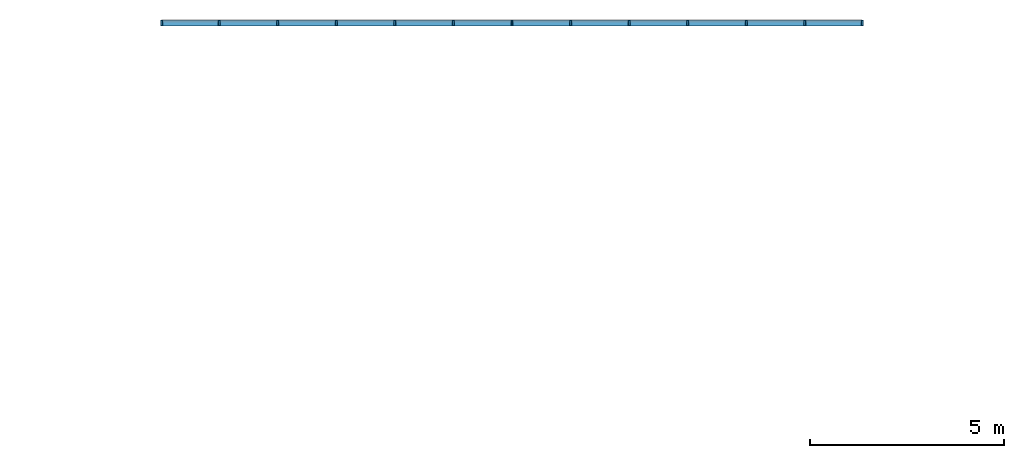
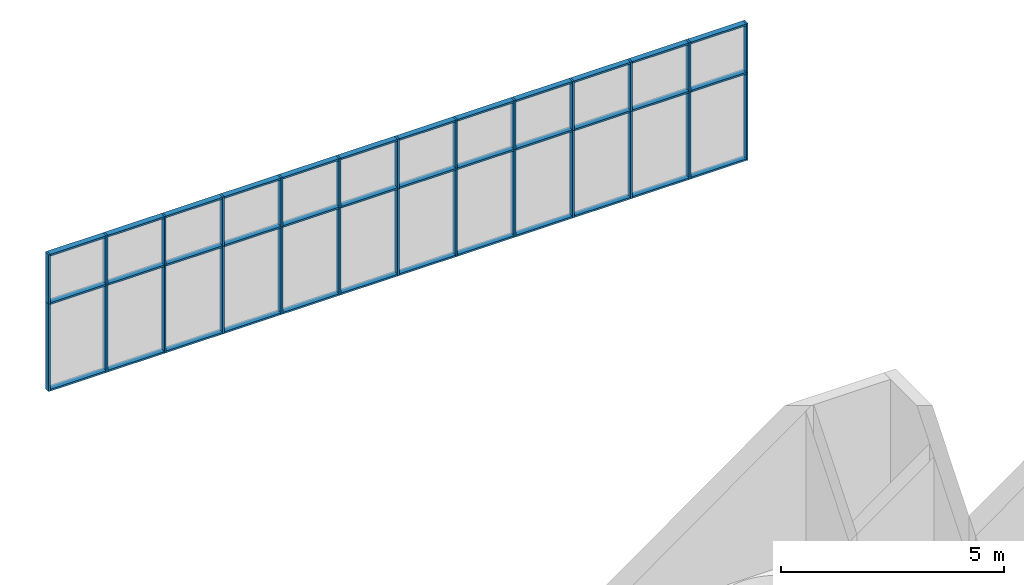
# One storey, part 3 of 11: 62 members, 1 element without a shape of its own.
"""IFC2X3 building model written with IfcOpenShell, lengths in millimetres."""

from ifc_helpers import new_model, entity, si_unit, converted_unit, direction, frame, frame_2d, origin, origin_2d_with_axis, place, context, subcontext, project, spatial, rectangle, extrude, element, aggregate, save


model = new_model("IFC2X3")

# Units and contexts
model_context = context("Model", 3, precision=1e-06, world=origin(), true_north=direction((2.0, 6.12303176911189e-17, 1.0)))
context_of_model = context(None, 3, precision=1e-06, world=origin(), true_north=direction((2.0, 6.12303176911189e-17, 1.0)))
body_context = subcontext(model_context, "Body", "Model", "MODEL_VIEW")
ifc_project = project(units=[si_unit("LENGTHUNIT", "METRE", prefix="MILLI"), si_unit("AREAUNIT", "SQUARE_METRE", prefix="MILLI"), si_unit("VOLUMEUNIT", "CUBIC_METRE", prefix="MILLI"), converted_unit("PLANEANGLEUNIT", "DEGREE", entity("IfcRatioMeasure", 0.0174532925199433), si_unit("PLANEANGLEUNIT", "RADIAN"), dimensions=[0, 0, 0, 0, 0, 0, 0]), si_unit("TIMEUNIT", "SECOND")], contexts=[model_context, context_of_model])

# Site, building, storey
site_placement = place(None, origin())
site = spatial("IfcSite", under=ifc_project, at=site_placement, CompositionType="ELEMENT")
building_placement = place(site_placement, origin())
building = spatial("IfcBuilding", under=site, at=building_placement, CompositionType="ELEMENT")
storey_placement = place(building_placement, frame((0.0, 0.0, 3750.0)))
storey = spatial("IfcBuildingStorey", under=building, at=storey_placement, Name="02. 2 etg.", CompositionType="ELEMENT", Elevation=3750.00000000068)

# Curtain wall, members
curtain_wall_placement = place(storey_placement, origin())
curtain_wall = element("IfcCurtainWall", 1, at=curtain_wall_placement, inside=storey, Name="Curtain Wall:Storefront", ObjectType="Curtain Wall:Storefront")
member_1_placement = place(storey_placement, origin())
member_1 = element("IfcMember", 2, at=member_1_placement, Name="Curtain Wall:Storefront:8486", ObjectType="Curtain Wall:Storefront:8486", context=body_context, shape_type="SweptSolid", body=[
    extrude(rectangle(XDim=1436.66666666667, YDim=150.000000000001, at=frame_2d((0.0, 1.08713038571295e-12), x_axis=(1.0, 0.0))), frame((28730.7845228414, 18980.0, 3700.0), z_axis=(0.0, 0.0, 1.0), x_axis=(-1.0, 0.0, 0.0)), (0.0, 0.0, 1.0), 49.9999999999995),
])
member_2_placement = place(storey_placement, origin())
member_2 = element("IfcMember", 3, at=member_2_placement, Name="Curtain Wall:Storefront:8486", ObjectType="Curtain Wall:Storefront:8486", context=body_context, shape_type="SweptSolid", body=[
    extrude(rectangle(XDim=1436.66666666667, YDim=150.000000000001, at=frame_2d((1.08002495835535e-12, 1.08713038571295e-12), x_axis=(1.0, 0.0))), frame((12127.4511895081, 18980.0, 0.0)), (0.0, 0.0, 1.0), 50.0),
])
member_3_placement = place(storey_placement, origin())
member_3 = element("IfcMember", 4, at=member_3_placement, Name="Curtain Wall:Storefront:8486", ObjectType="Curtain Wall:Storefront:8486", context=body_context, shape_type="SweptSolid", body=[
    extrude(rectangle(XDim=149.999999999998, YDim=50.0000000000016, at=frame_2d((-1.08002495835535e-12, -2.16715534406831e-12), x_axis=(1.0, 0.0))), frame((29474.1178561748, 18980.0, 0.0), z_axis=(0.0, 0.0, 1.0), x_axis=(0.0, 1.0, 0.0)), (0.0, 0.0, 1.0), 2400.0),
])
member_4_placement = place(storey_placement, origin())
member_4 = element("IfcMember", 5, at=member_4_placement, Name="Curtain Wall:Storefront:8486", ObjectType="Curtain Wall:Storefront:8486", context=body_context, shape_type="SweptSolid", body=[
    extrude(rectangle(XDim=49.9999999999995, YDim=149.999999999998, at=frame_2d((2.16715534406831e-12, 1.08002495835535e-12), x_axis=(1.0, 0.0))), frame((11384.1178561748, 18980.0, 2400.0)), (0.0, 0.0, 1.0), 1349.99999999993),
])
member_5_placement = place(storey_placement, origin())
member_5 = element("IfcMember", 6, at=member_5_placement, Name="Curtain Wall:Storefront:8486", ObjectType="Curtain Wall:Storefront:8486", context=body_context, shape_type="SweptSolid", body=[
    extrude(rectangle(XDim=1436.66666666667, YDim=150.000000000001, at=frame_2d((-1.08002495835535e-12, 1.08713038571295e-12), x_axis=(1.0, 0.0))), frame((12127.4511895081, 18980.0, 3700.0), z_axis=(0.0, 0.0, 1.0), x_axis=(-1.0, 0.0, 0.0)), (0.0, 0.0, 1.0), 49.9999999999995),
])
member_6_placement = place(storey_placement, origin())
member_6 = element("IfcMember", 7, at=member_6_placement, Name="Curtain Wall:Storefront:8486", ObjectType="Curtain Wall:Storefront:8486", context=body_context, shape_type="SweptSolid", body=[
    extrude(rectangle(XDim=1461.66666666667, YDim=150.000000000001, at=frame_2d((1.08002495835535e-12, 0.0), x_axis=(1.0, 0.0))), frame((13626.6178561748, 18980.0, 3700.0), z_axis=(0.0, 0.0, 1.0), x_axis=(-1.0, 0.0, 0.0)), (0.0, 0.0, 1.0), 49.9999999999995),
])
member_7_placement = place(storey_placement, origin())
member_7 = element("IfcMember", 8, at=member_7_placement, Name="Curtain Wall:Storefront:8486", ObjectType="Curtain Wall:Storefront:8486", context=body_context, shape_type="SweptSolid", body=[
    extrude(rectangle(XDim=1461.66666666667, YDim=150.000000000001, at=frame_2d((-1.08002495835535e-12, 0.0), x_axis=(1.0, 0.0))), frame((15138.2845228414, 18980.0, 3700.0), z_axis=(0.0, 0.0, 1.0), x_axis=(-1.0, 0.0, 0.0)), (0.0, 0.0, 1.0), 49.9999999999995),
])
member_8_placement = place(storey_placement, origin())
member_8 = element("IfcMember", 9, at=member_8_placement, Name="Curtain Wall:Storefront:8486", ObjectType="Curtain Wall:Storefront:8486", context=body_context, shape_type="SweptSolid", body=[
    extrude(rectangle(XDim=1461.66666666667, YDim=150.000000000001, at=frame_2d((-1.08002495835535e-12, 0.0), x_axis=(1.0, 0.0))), frame((16649.9511895081, 18980.0, 3700.0), z_axis=(0.0, 0.0, 1.0), x_axis=(-1.0, 0.0, 0.0)), (0.0, 0.0, 1.0), 49.9999999999995),
])
member_9_placement = place(storey_placement, origin())
member_9 = element("IfcMember", 10, at=member_9_placement, Name="Curtain Wall:Storefront:8486", ObjectType="Curtain Wall:Storefront:8486", context=body_context, shape_type="SweptSolid", body=[
    extrude(rectangle(XDim=1461.66666666666, YDim=150.000000000001, at=frame_2d((1.08002495835535e-12, 1.08713038571295e-12), x_axis=(1.0, 0.0))), frame((18161.6178561748, 18980.0, 3700.0), z_axis=(0.0, 0.0, 1.0), x_axis=(-1.0, 0.0, 0.0)), (0.0, 0.0, 1.0), 49.9999999999995),
])
member_10_placement = place(storey_placement, origin())
member_10 = element("IfcMember", 11, at=member_10_placement, Name="Curtain Wall:Storefront:8486", ObjectType="Curtain Wall:Storefront:8486", context=body_context, shape_type="SweptSolid", body=[
    extrude(rectangle(XDim=1461.66666666666, YDim=150.000000000001, at=frame_2d((1.08002495835535e-12, 0.0), x_axis=(1.0, 0.0))), frame((19673.2845228414, 18980.0, 3700.0), z_axis=(0.0, 0.0, 1.0), x_axis=(-1.0, 0.0, 0.0)), (0.0, 0.0, 1.0), 49.9999999999995),
])
member_11_placement = place(storey_placement, origin())
member_11 = element("IfcMember", 12, at=member_11_placement, Name="Curtain Wall:Storefront:8486", ObjectType="Curtain Wall:Storefront:8486", context=body_context, shape_type="SweptSolid", body=[
    extrude(rectangle(XDim=1461.66666666666, YDim=150.000000000001, at=frame_2d((0.0, 2.16715534406831e-12), x_axis=(1.0, 0.0))), frame((21184.9511895081, 18980.0, 3700.0), z_axis=(0.0, 0.0, 1.0), x_axis=(-1.0, 0.0, 0.0)), (0.0, 0.0, 1.0), 49.9999999999995),
])
member_12_placement = place(storey_placement, origin())
member_12 = element("IfcMember", 13, at=member_12_placement, Name="Curtain Wall:Storefront:8486", ObjectType="Curtain Wall:Storefront:8486", context=body_context, shape_type="SweptSolid", body=[
    extrude(rectangle(XDim=1461.66666666666, YDim=150.000000000001, at=frame_2d((0.0, 1.08713038571295e-12), x_axis=(1.0, 0.0))), frame((22696.6178561748, 18980.0, 3700.0), z_axis=(0.0, 0.0, 1.0), x_axis=(-1.0, 0.0, 0.0)), (0.0, 0.0, 1.0), 49.9999999999995),
])
member_13_placement = place(storey_placement, origin())
member_13 = element("IfcMember", 14, at=member_13_placement, Name="Curtain Wall:Storefront:8486", ObjectType="Curtain Wall:Storefront:8486", context=body_context, shape_type="SweptSolid", body=[
    extrude(rectangle(XDim=1461.66666666666, YDim=150.000000000001, at=origin_2d_with_axis()), frame((24208.2845228414, 18980.0, 3700.0), z_axis=(0.0, 0.0, 1.0), x_axis=(-1.0, 0.0, 0.0)), (0.0, 0.0, 1.0), 49.9999999999995),
])
member_14_placement = place(storey_placement, origin())
member_14 = element("IfcMember", 15, at=member_14_placement, Name="Curtain Wall:Storefront:8486", ObjectType="Curtain Wall:Storefront:8486", context=body_context, shape_type="SweptSolid", body=[
    extrude(rectangle(XDim=1461.66666666666, YDim=150.000000000001, at=origin_2d_with_axis()), frame((25719.9511895081, 18980.0, 3700.0), z_axis=(0.0, 0.0, 1.0), x_axis=(-1.0, 0.0, 0.0)), (0.0, 0.0, 1.0), 49.9999999999995),
])
member_15_placement = place(storey_placement, origin())
member_15 = element("IfcMember", 16, at=member_15_placement, Name="Curtain Wall:Storefront:8486", ObjectType="Curtain Wall:Storefront:8486", context=body_context, shape_type="SweptSolid", body=[
    extrude(rectangle(XDim=1461.66666666666, YDim=150.000000000001, at=origin_2d_with_axis()), frame((27231.6178561748, 18980.0, 3700.0), z_axis=(0.0, 0.0, 1.0), x_axis=(-1.0, 0.0, 0.0)), (0.0, 0.0, 1.0), 49.9999999999995),
])
member_16_placement = place(storey_placement, origin())
member_16 = element("IfcMember", 17, at=member_16_placement, Name="Curtain Wall:Storefront:8486", ObjectType="Curtain Wall:Storefront:8486", context=body_context, shape_type="SweptSolid", body=[
    extrude(rectangle(XDim=1461.66666666666, YDim=150.000000000001, at=frame_2d((1.08002495835535e-12, 0.0), x_axis=(1.0, 0.0))), frame((13626.6178561748, 18980.0, 0.0)), (0.0, 0.0, 1.0), 50.0),
])
member_17_placement = place(storey_placement, origin())
member_17 = element("IfcMember", 18, at=member_17_placement, Name="Curtain Wall:Storefront:8486", ObjectType="Curtain Wall:Storefront:8486", context=body_context, shape_type="SweptSolid", body=[
    extrude(rectangle(XDim=1461.66666666666, YDim=150.000000000001, at=frame_2d((1.08002495835535e-12, 0.0), x_axis=(1.0, 0.0))), frame((15138.2845228414, 18980.0, 0.0)), (0.0, 0.0, 1.0), 50.0),
])
member_18_placement = place(storey_placement, origin())
member_18 = element("IfcMember", 19, at=member_18_placement, Name="Curtain Wall:Storefront:8486", ObjectType="Curtain Wall:Storefront:8486", context=body_context, shape_type="SweptSolid", body=[
    extrude(rectangle(XDim=1461.66666666666, YDim=150.000000000001, at=frame_2d((-1.08002495835535e-12, 0.0), x_axis=(1.0, 0.0))), frame((16649.9511895081, 18980.0, 0.0)), (0.0, 0.0, 1.0), 50.0),
])
member_19_placement = place(storey_placement, origin())
member_19 = element("IfcMember", 20, at=member_19_placement, Name="Curtain Wall:Storefront:8486", ObjectType="Curtain Wall:Storefront:8486", context=body_context, shape_type="SweptSolid", body=[
    extrude(rectangle(XDim=1461.66666666666, YDim=150.000000000001, at=frame_2d((1.08002495835535e-12, 1.08713038571295e-12), x_axis=(1.0, 0.0))), frame((18161.6178561748, 18980.0, 0.0)), (0.0, 0.0, 1.0), 50.0),
])
member_20_placement = place(storey_placement, origin())
member_20 = element("IfcMember", 21, at=member_20_placement, Name="Curtain Wall:Storefront:8486", ObjectType="Curtain Wall:Storefront:8486", context=body_context, shape_type="SweptSolid", body=[
    extrude(rectangle(XDim=1461.66666666667, YDim=150.000000000001, at=frame_2d((-1.08002495835535e-12, 2.16715534406831e-12), x_axis=(1.0, 0.0))), frame((19673.2845228414, 18980.0, 0.0)), (0.0, 0.0, 1.0), 50.0),
])
member_21_placement = place(storey_placement, origin())
member_21 = element("IfcMember", 22, at=member_21_placement, Name="Curtain Wall:Storefront:8486", ObjectType="Curtain Wall:Storefront:8486", context=body_context, shape_type="SweptSolid", body=[
    extrude(rectangle(XDim=1461.66666666666, YDim=150.000000000001, at=origin_2d_with_axis()), frame((21184.9511895081, 18980.0, 0.0)), (0.0, 0.0, 1.0), 50.0),
])
member_22_placement = place(storey_placement, origin())
member_22 = element("IfcMember", 23, at=member_22_placement, Name="Curtain Wall:Storefront:8486", ObjectType="Curtain Wall:Storefront:8486", context=body_context, shape_type="SweptSolid", body=[
    extrude(rectangle(XDim=1461.66666666666, YDim=150.000000000001, at=frame_2d((0.0, 1.08713038571295e-12), x_axis=(1.0, 0.0))), frame((22696.6178561748, 18980.0, 0.0)), (0.0, 0.0, 1.0), 50.0),
])
member_23_placement = place(storey_placement, origin())
member_23 = element("IfcMember", 24, at=member_23_placement, Name="Curtain Wall:Storefront:8486", ObjectType="Curtain Wall:Storefront:8486", context=body_context, shape_type="SweptSolid", body=[
    extrude(rectangle(XDim=1461.66666666666, YDim=150.000000000001, at=origin_2d_with_axis()), frame((24208.2845228414, 18980.0, 0.0)), (0.0, 0.0, 1.0), 50.0),
])
member_24_placement = place(storey_placement, origin())
member_24 = element("IfcMember", 25, at=member_24_placement, Name="Curtain Wall:Storefront:8486", ObjectType="Curtain Wall:Storefront:8486", context=body_context, shape_type="SweptSolid", body=[
    extrude(rectangle(XDim=1461.66666666666, YDim=150.000000000001, at=origin_2d_with_axis()), frame((25719.9511895081, 18980.0, 0.0)), (0.0, 0.0, 1.0), 50.0),
])
member_25_placement = place(storey_placement, origin())
member_25 = element("IfcMember", 26, at=member_25_placement, Name="Curtain Wall:Storefront:8486", ObjectType="Curtain Wall:Storefront:8486", context=body_context, shape_type="SweptSolid", body=[
    extrude(rectangle(XDim=1461.66666666666, YDim=150.000000000001, at=origin_2d_with_axis()), frame((27231.6178561748, 18980.0, 0.0)), (0.0, 0.0, 1.0), 50.0),
])
member_26_placement = place(storey_placement, origin())
member_26 = element("IfcMember", 27, at=member_26_placement, Name="Curtain Wall:Storefront:8486", ObjectType="Curtain Wall:Storefront:8486", context=body_context, shape_type="SweptSolid", body=[
    extrude(rectangle(XDim=1436.66666666666, YDim=150.000000000001, at=frame_2d((-2.1600499167107e-12, 1.08713038571295e-12), x_axis=(1.0, 0.0))), frame((28730.7845228414, 18980.0, 0.0)), (0.0, 0.0, 1.0), 50.0),
])
member_27_placement = place(storey_placement, origin())
member_27 = element("IfcMember", 28, at=member_27_placement, Name="Curtain Wall:Storefront:8486", ObjectType="Curtain Wall:Storefront:8486", context=body_context, shape_type="SweptSolid", body=[
    extrude(rectangle(XDim=150.000000000001, YDim=50.0000000000016, at=origin_2d_with_axis()), frame((29474.1178561748, 18980.0, 2400.0), z_axis=(0.0, 0.0, 1.0), x_axis=(0.0, 1.0, 0.0)), (0.0, 0.0, 1.0), 1349.99999999993),
])
member_28_placement = place(storey_placement, origin())
member_28 = element("IfcMember", 29, at=member_28_placement, Name="Curtain Wall:Storefront:8486", ObjectType="Curtain Wall:Storefront:8486", context=body_context, shape_type="SweptSolid", body=[
    extrude(rectangle(XDim=50.0000000000016, YDim=150.000000000001, at=origin_2d_with_axis()), frame((11384.1178561748, 18980.0, 0.0)), (0.0, 0.0, 1.0), 2400.0),
])
member_29_placement = place(storey_placement, origin())
member_29 = element("IfcMember", 30, at=member_29_placement, Name="Curtain Wall:Storefront:8486", ObjectType="Curtain Wall:Storefront:8486", context=body_context, shape_type="SweptSolid", body=[
    extrude(rectangle(XDim=1436.66666666667, YDim=150.000000000001, at=frame_2d((1.08002495835535e-12, 1.08713038571295e-12), x_axis=(1.0, 0.0))), frame((12127.4511895081, 18980.0, 2375.0), z_axis=(0.0, 0.0, 1.0), x_axis=(-1.0, 0.0, 0.0)), (0.0, 0.0, 1.0), 49.9999999999995),
])
member_30_placement = place(storey_placement, origin())
member_30 = element("IfcMember", 31, at=member_30_placement, Name="Curtain Wall:Storefront:8486", ObjectType="Curtain Wall:Storefront:8486", context=body_context, shape_type="SweptSolid", body=[
    extrude(rectangle(XDim=1461.66666666667, YDim=149.999999999998, at=frame_2d((1.08002495835535e-12, -1.08002495835535e-12), x_axis=(1.0, 0.0))), frame((13626.6178561748, 18980.0, 2375.0), z_axis=(0.0, 0.0, 1.0), x_axis=(-1.0, 0.0, 0.0)), (0.0, 0.0, 1.0), 49.9999999999995),
])
member_31_placement = place(storey_placement, origin())
member_31 = element("IfcMember", 32, at=member_31_placement, Name="Curtain Wall:Storefront:8486", ObjectType="Curtain Wall:Storefront:8486", context=body_context, shape_type="SweptSolid", body=[
    extrude(rectangle(XDim=1461.66666666667, YDim=149.999999999998, at=frame_2d((-1.08002495835535e-12, 1.08002495835535e-12), x_axis=(1.0, 0.0))), frame((15138.2845228414, 18980.0, 2375.0), z_axis=(0.0, 0.0, 1.0), x_axis=(-1.0, 0.0, 0.0)), (0.0, 0.0, 1.0), 49.9999999999995),
])
member_32_placement = place(storey_placement, origin())
member_32 = element("IfcMember", 33, at=member_32_placement, Name="Curtain Wall:Storefront:8486", ObjectType="Curtain Wall:Storefront:8486", context=body_context, shape_type="SweptSolid", body=[
    extrude(rectangle(XDim=1461.66666666667, YDim=149.999999999998, at=frame_2d((-1.08002495835535e-12, -1.08002495835535e-12), x_axis=(1.0, 0.0))), frame((16649.9511895081, 18980.0, 2375.0), z_axis=(0.0, 0.0, 1.0), x_axis=(-1.0, 0.0, 0.0)), (0.0, 0.0, 1.0), 49.9999999999995),
])
member_33_placement = place(storey_placement, origin())
member_33 = element("IfcMember", 34, at=member_33_placement, Name="Curtain Wall:Storefront:8486", ObjectType="Curtain Wall:Storefront:8486", context=body_context, shape_type="SweptSolid", body=[
    extrude(rectangle(XDim=1461.66666666666, YDim=150.000000000001, at=frame_2d((1.08002495835535e-12, 1.08002495835535e-12), x_axis=(1.0, 0.0))), frame((18161.6178561748, 18980.0, 2375.0), z_axis=(0.0, 0.0, 1.0), x_axis=(-1.0, 0.0, 0.0)), (0.0, 0.0, 1.0), 49.9999999999995),
])
member_34_placement = place(storey_placement, origin())
member_34 = element("IfcMember", 35, at=member_34_placement, Name="Curtain Wall:Storefront:8486", ObjectType="Curtain Wall:Storefront:8486", context=body_context, shape_type="SweptSolid", body=[
    extrude(rectangle(XDim=1461.66666666666, YDim=150.000000000001, at=frame_2d((1.08002495835535e-12, 0.0), x_axis=(1.0, 0.0))), frame((19673.2845228414, 18980.0, 2375.0), z_axis=(0.0, 0.0, 1.0), x_axis=(-1.0, 0.0, 0.0)), (0.0, 0.0, 1.0), 49.9999999999995),
])
member_35_placement = place(storey_placement, origin())
member_35 = element("IfcMember", 36, at=member_35_placement, Name="Curtain Wall:Storefront:8486", ObjectType="Curtain Wall:Storefront:8486", context=body_context, shape_type="SweptSolid", body=[
    extrude(rectangle(XDim=1461.66666666666, YDim=150.000000000001, at=frame_2d((0.0, 2.16715534406831e-12), x_axis=(1.0, 0.0))), frame((21184.9511895081, 18980.0, 2375.0), z_axis=(0.0, 0.0, 1.0), x_axis=(-1.0, 0.0, 0.0)), (0.0, 0.0, 1.0), 49.9999999999995),
])
member_36_placement = place(storey_placement, origin())
member_36 = element("IfcMember", 37, at=member_36_placement, Name="Curtain Wall:Storefront:8486", ObjectType="Curtain Wall:Storefront:8486", context=body_context, shape_type="SweptSolid", body=[
    extrude(rectangle(XDim=1461.66666666666, YDim=149.999999999998, at=frame_2d((0.0, 2.16715534406831e-12), x_axis=(1.0, 0.0))), frame((22696.6178561748, 18980.0, 2375.0), z_axis=(0.0, 0.0, 1.0), x_axis=(-1.0, 0.0, 0.0)), (0.0, 0.0, 1.0), 49.9999999999995),
])
member_37_placement = place(storey_placement, origin())
member_37 = element("IfcMember", 38, at=member_37_placement, Name="Curtain Wall:Storefront:8486", ObjectType="Curtain Wall:Storefront:8486", context=body_context, shape_type="SweptSolid", body=[
    extrude(rectangle(XDim=1461.66666666666, YDim=149.999999999998, at=frame_2d((0.0, -1.08002495835535e-12), x_axis=(1.0, 0.0))), frame((24208.2845228414, 18980.0, 2375.0), z_axis=(0.0, 0.0, 1.0), x_axis=(-1.0, 0.0, 0.0)), (0.0, 0.0, 1.0), 49.9999999999995),
])
member_38_placement = place(storey_placement, origin())
member_38 = element("IfcMember", 39, at=member_38_placement, Name="Curtain Wall:Storefront:8486", ObjectType="Curtain Wall:Storefront:8486", context=body_context, shape_type="SweptSolid", body=[
    extrude(rectangle(XDim=1461.66666666666, YDim=149.999999999998, at=frame_2d((0.0, 1.08002495835535e-12), x_axis=(1.0, 0.0))), frame((25719.9511895081, 18980.0, 2375.0), z_axis=(0.0, 0.0, 1.0), x_axis=(-1.0, 0.0, 0.0)), (0.0, 0.0, 1.0), 49.9999999999995),
])
member_39_placement = place(storey_placement, origin())
member_39 = element("IfcMember", 40, at=member_39_placement, Name="Curtain Wall:Storefront:8486", ObjectType="Curtain Wall:Storefront:8486", context=body_context, shape_type="SweptSolid", body=[
    extrude(rectangle(XDim=1461.66666666666, YDim=149.999999999998, at=frame_2d((0.0, -1.08002495835535e-12), x_axis=(1.0, 0.0))), frame((27231.6178561748, 18980.0, 2375.0), z_axis=(0.0, 0.0, 1.0), x_axis=(-1.0, 0.0, 0.0)), (0.0, 0.0, 1.0), 49.9999999999995),
])
member_40_placement = place(storey_placement, origin())
member_40 = element("IfcMember", 41, at=member_40_placement, Name="Curtain Wall:Storefront:8486", ObjectType="Curtain Wall:Storefront:8486", context=body_context, shape_type="SweptSolid", body=[
    extrude(rectangle(XDim=1436.66666666667, YDim=150.000000000001, at=frame_2d((0.0, 1.08713038571295e-12), x_axis=(1.0, 0.0))), frame((28730.7845228414, 18980.0, 2375.0), z_axis=(0.0, 0.0, 1.0), x_axis=(-1.0, 0.0, 0.0)), (0.0, 0.0, 1.0), 49.9999999999995),
])
member_41_placement = place(storey_placement, origin())
member_41 = element("IfcMember", 42, at=member_41_placement, Name="Curtain Wall:Storefront:8486", ObjectType="Curtain Wall:Storefront:8486", context=body_context, shape_type="SweptSolid", body=[
    extrude(rectangle(XDim=149.999999999998, YDim=49.9999999999995, at=frame_2d((-1.08002495835535e-12, -1.08357767203415e-12), x_axis=(1.0, 0.0))), frame((12870.7845228414, 18980.0, 0.0), z_axis=(0.0, 0.0, 1.0), x_axis=(0.0, 1.0, 0.0)), (0.0, 0.0, 1.0), 2400.0),
])
member_42_placement = place(storey_placement, origin())
member_42 = element("IfcMember", 43, at=member_42_placement, Name="Curtain Wall:Storefront:8486", ObjectType="Curtain Wall:Storefront:8486", context=body_context, shape_type="SweptSolid", body=[
    extrude(rectangle(XDim=149.999999999998, YDim=49.9999999999995, at=frame_2d((1.08002495835535e-12, 1.08357767203415e-12), x_axis=(1.0, 0.0))), frame((14382.4511895081, 18980.0, 0.0), z_axis=(0.0, 0.0, 1.0), x_axis=(0.0, 1.0, 0.0)), (0.0, 0.0, 1.0), 2400.0),
])
member_43_placement = place(storey_placement, origin())
member_43 = element("IfcMember", 44, at=member_43_placement, Name="Curtain Wall:Storefront:8486", ObjectType="Curtain Wall:Storefront:8486", context=body_context, shape_type="SweptSolid", body=[
    extrude(rectangle(XDim=149.999999999998, YDim=49.9999999999995, at=frame_2d((1.08002495835535e-12, -1.08357767203415e-12), x_axis=(1.0, 0.0))), frame((15894.1178561748, 18980.0, 0.0), z_axis=(0.0, 0.0, 1.0), x_axis=(0.0, 1.0, 0.0)), (0.0, 0.0, 1.0), 2400.0),
])
member_44_placement = place(storey_placement, origin())
member_44 = element("IfcMember", 45, at=member_44_placement, Name="Curtain Wall:Storefront:8486", ObjectType="Curtain Wall:Storefront:8486", context=body_context, shape_type="SweptSolid", body=[
    extrude(rectangle(XDim=149.999999999998, YDim=49.9999999999995, at=frame_2d((1.08002495835535e-12, 1.08357767203415e-12), x_axis=(1.0, 0.0))), frame((17405.7845228414, 18980.0, 0.0), z_axis=(0.0, 0.0, 1.0), x_axis=(0.0, 1.0, 0.0)), (0.0, 0.0, 1.0), 2400.0),
])
member_45_placement = place(storey_placement, origin())
member_45 = element("IfcMember", 46, at=member_45_placement, Name="Curtain Wall:Storefront:8486", ObjectType="Curtain Wall:Storefront:8486", context=body_context, shape_type="SweptSolid", body=[
    extrude(rectangle(XDim=149.999999999998, YDim=49.9999999999995, at=frame_2d((-1.08002495835535e-12, -1.08357767203415e-12), x_axis=(1.0, 0.0))), frame((18917.4511895081, 18980.0, 0.0), z_axis=(0.0, 0.0, 1.0), x_axis=(0.0, 1.0, 0.0)), (0.0, 0.0, 1.0), 2400.0),
])
member_46_placement = place(storey_placement, origin())
member_46 = element("IfcMember", 47, at=member_46_placement, Name="Curtain Wall:Storefront:8486", ObjectType="Curtain Wall:Storefront:8486", context=body_context, shape_type="SweptSolid", body=[
    extrude(rectangle(XDim=149.999999999998, YDim=50.0000000000016, at=frame_2d((1.08002495835535e-12, -2.16715534406831e-12), x_axis=(1.0, 0.0))), frame((20429.1178561748, 18980.0, 0.0), z_axis=(0.0, 0.0, 1.0), x_axis=(0.0, 1.0, 0.0)), (0.0, 0.0, 1.0), 2400.0),
])
member_47_placement = place(storey_placement, origin())
member_47 = element("IfcMember", 48, at=member_47_placement, Name="Curtain Wall:Storefront:8486", ObjectType="Curtain Wall:Storefront:8486", context=body_context, shape_type="SweptSolid", body=[
    extrude(rectangle(XDim=149.999999999998, YDim=50.0000000000016, at=frame_2d((1.08002495835535e-12, 2.16715534406831e-12), x_axis=(1.0, 0.0))), frame((21940.7845228414, 18980.0, 0.0), z_axis=(0.0, 0.0, 1.0), x_axis=(0.0, 1.0, 0.0)), (0.0, 0.0, 1.0), 2400.0),
])
member_48_placement = place(storey_placement, origin())
member_48 = element("IfcMember", 49, at=member_48_placement, Name="Curtain Wall:Storefront:8486", ObjectType="Curtain Wall:Storefront:8486", context=body_context, shape_type="SweptSolid", body=[
    extrude(rectangle(XDim=149.999999999998, YDim=50.0000000000016, at=frame_2d((-1.08002495835535e-12, 2.16715534406831e-12), x_axis=(1.0, 0.0))), frame((23452.4511895081, 18980.0, 0.0), z_axis=(0.0, 0.0, 1.0), x_axis=(0.0, 1.0, 0.0)), (0.0, 0.0, 1.0), 2400.0),
])
member_49_placement = place(storey_placement, origin())
member_49 = element("IfcMember", 50, at=member_49_placement, Name="Curtain Wall:Storefront:8486", ObjectType="Curtain Wall:Storefront:8486", context=body_context, shape_type="SweptSolid", body=[
    extrude(rectangle(XDim=149.999999999998, YDim=50.0000000000016, at=frame_2d((1.08002495835535e-12, 2.16715534406831e-12), x_axis=(1.0, 0.0))), frame((24964.1178561748, 18980.0, 0.0), z_axis=(0.0, 0.0, 1.0), x_axis=(0.0, 1.0, 0.0)), (0.0, 0.0, 1.0), 2400.0),
])
member_50_placement = place(storey_placement, origin())
member_50 = element("IfcMember", 51, at=member_50_placement, Name="Curtain Wall:Storefront:8486", ObjectType="Curtain Wall:Storefront:8486", context=body_context, shape_type="SweptSolid", body=[
    extrude(rectangle(XDim=149.999999999998, YDim=50.0000000000016, at=frame_2d((1.08002495835535e-12, -2.16715534406831e-12), x_axis=(1.0, 0.0))), frame((26475.7845228414, 18980.0, 0.0), z_axis=(0.0, 0.0, 1.0), x_axis=(0.0, 1.0, 0.0)), (0.0, 0.0, 1.0), 2400.0),
])
member_51_placement = place(storey_placement, origin())
member_51 = element("IfcMember", 52, at=member_51_placement, Name="Curtain Wall:Storefront:8486", ObjectType="Curtain Wall:Storefront:8486", context=body_context, shape_type="SweptSolid", body=[
    extrude(rectangle(XDim=149.999999999998, YDim=50.0000000000016, at=frame_2d((1.08002495835535e-12, 2.16715534406831e-12), x_axis=(1.0, 0.0))), frame((27987.4511895081, 18980.0, 0.0), z_axis=(0.0, 0.0, 1.0), x_axis=(0.0, 1.0, 0.0)), (0.0, 0.0, 1.0), 2400.0),
])
member_52_placement = place(storey_placement, origin())
member_52 = element("IfcMember", 53, at=member_52_placement, Name="Curtain Wall:Storefront:8486", ObjectType="Curtain Wall:Storefront:8486", context=body_context, shape_type="SweptSolid", body=[
    extrude(rectangle(XDim=149.999999999998, YDim=49.9999999999995, at=frame_2d((-1.08002495835535e-12, -1.08357767203415e-12), x_axis=(1.0, 0.0))), frame((12870.7845228415, 18980.0, 2400.0), z_axis=(0.0, 0.0, 1.0), x_axis=(0.0, 1.0, 0.0)), (0.0, 0.0, 1.0), 1349.99999999993),
])
member_53_placement = place(storey_placement, origin())
member_53 = element("IfcMember", 54, at=member_53_placement, Name="Curtain Wall:Storefront:8486", ObjectType="Curtain Wall:Storefront:8486", context=body_context, shape_type="SweptSolid", body=[
    extrude(rectangle(XDim=149.999999999998, YDim=49.9999999999995, at=frame_2d((1.08002495835535e-12, 1.08357767203415e-12), x_axis=(1.0, 0.0))), frame((14382.4511895081, 18980.0, 2400.0), z_axis=(0.0, 0.0, 1.0), x_axis=(0.0, 1.0, 0.0)), (0.0, 0.0, 1.0), 1349.99999999993),
])
member_54_placement = place(storey_placement, origin())
member_54 = element("IfcMember", 55, at=member_54_placement, Name="Curtain Wall:Storefront:8486", ObjectType="Curtain Wall:Storefront:8486", context=body_context, shape_type="SweptSolid", body=[
    extrude(rectangle(XDim=149.999999999998, YDim=49.9999999999995, at=frame_2d((1.08002495835535e-12, -1.08357767203415e-12), x_axis=(1.0, 0.0))), frame((15894.1178561748, 18980.0, 2400.0), z_axis=(0.0, 0.0, 1.0), x_axis=(0.0, 1.0, 0.0)), (0.0, 0.0, 1.0), 1349.99999999993),
])
member_55_placement = place(storey_placement, origin())
member_55 = element("IfcMember", 56, at=member_55_placement, Name="Curtain Wall:Storefront:8486", ObjectType="Curtain Wall:Storefront:8486", context=body_context, shape_type="SweptSolid", body=[
    extrude(rectangle(XDim=149.999999999998, YDim=49.9999999999995, at=frame_2d((1.08002495835535e-12, -1.08357767203415e-12), x_axis=(1.0, 0.0))), frame((17405.7845228414, 18980.0, 2400.0), z_axis=(0.0, 0.0, 1.0), x_axis=(0.0, 1.0, 0.0)), (0.0, 0.0, 1.0), 1349.99999999993),
])
member_56_placement = place(storey_placement, origin())
member_56 = element("IfcMember", 57, at=member_56_placement, Name="Curtain Wall:Storefront:8486", ObjectType="Curtain Wall:Storefront:8486", context=body_context, shape_type="SweptSolid", body=[
    extrude(rectangle(XDim=149.999999999998, YDim=49.9999999999995, at=frame_2d((-1.08002495835535e-12, -1.08357767203415e-12), x_axis=(1.0, 0.0))), frame((18917.4511895081, 18980.0, 2400.0), z_axis=(0.0, 0.0, 1.0), x_axis=(0.0, 1.0, 0.0)), (0.0, 0.0, 1.0), 1349.99999999993),
])
member_57_placement = place(storey_placement, origin())
member_57 = element("IfcMember", 58, at=member_57_placement, Name="Curtain Wall:Storefront:8486", ObjectType="Curtain Wall:Storefront:8486", context=body_context, shape_type="SweptSolid", body=[
    extrude(rectangle(XDim=149.999999999998, YDim=49.9999999999973, at=frame_2d((-1.08002495835535e-12, 0.0), x_axis=(1.0, 0.0))), frame((20429.1178561748, 18980.0, 2400.0), z_axis=(0.0, 0.0, 1.0), x_axis=(0.0, 1.0, 0.0)), (0.0, 0.0, 1.0), 1349.99999999993),
])
member_58_placement = place(storey_placement, origin())
member_58 = element("IfcMember", 59, at=member_58_placement, Name="Curtain Wall:Storefront:8486", ObjectType="Curtain Wall:Storefront:8486", context=body_context, shape_type="SweptSolid", body=[
    extrude(rectangle(XDim=149.999999999998, YDim=49.9999999999973, at=frame_2d((-1.08002495835535e-12, 0.0), x_axis=(1.0, 0.0))), frame((21940.7845228414, 18980.0, 2400.0), z_axis=(0.0, 0.0, 1.0), x_axis=(0.0, 1.0, 0.0)), (0.0, 0.0, 1.0), 1349.99999999993),
])
member_59_placement = place(storey_placement, origin())
member_59 = element("IfcMember", 60, at=member_59_placement, Name="Curtain Wall:Storefront:8486", ObjectType="Curtain Wall:Storefront:8486", context=body_context, shape_type="SweptSolid", body=[
    extrude(rectangle(XDim=149.999999999998, YDim=49.9999999999973, at=frame_2d((-1.08002495835535e-12, 0.0), x_axis=(1.0, 0.0))), frame((23452.4511895081, 18980.0, 2400.0), z_axis=(0.0, 0.0, 1.0), x_axis=(0.0, 1.0, 0.0)), (0.0, 0.0, 1.0), 1349.99999999993),
])
member_60_placement = place(storey_placement, origin())
member_60 = element("IfcMember", 61, at=member_60_placement, Name="Curtain Wall:Storefront:8486", ObjectType="Curtain Wall:Storefront:8486", context=body_context, shape_type="SweptSolid", body=[
    extrude(rectangle(XDim=149.999999999998, YDim=49.9999999999973, at=frame_2d((1.08002495835535e-12, 0.0), x_axis=(1.0, 0.0))), frame((24964.1178561748, 18980.0, 2400.0), z_axis=(0.0, 0.0, 1.0), x_axis=(0.0, 1.0, 0.0)), (0.0, 0.0, 1.0), 1349.99999999993),
])
member_61_placement = place(storey_placement, origin())
member_61 = element("IfcMember", 62, at=member_61_placement, Name="Curtain Wall:Storefront:8486", ObjectType="Curtain Wall:Storefront:8486", context=body_context, shape_type="SweptSolid", body=[
    extrude(rectangle(XDim=149.999999999998, YDim=49.9999999999973, at=frame_2d((1.08002495835535e-12, 0.0), x_axis=(1.0, 0.0))), frame((26475.7845228414, 18980.0, 2400.0), z_axis=(0.0, 0.0, 1.0), x_axis=(0.0, 1.0, 0.0)), (0.0, 0.0, 1.0), 1349.99999999993),
])
member_62_placement = place(storey_placement, origin())
member_62 = element("IfcMember", 63, at=member_62_placement, Name="Curtain Wall:Storefront:8486", ObjectType="Curtain Wall:Storefront:8486", context=body_context, shape_type="SweptSolid", body=[
    extrude(rectangle(XDim=149.999999999998, YDim=49.9999999999973, at=frame_2d((1.08002495835535e-12, 0.0), x_axis=(1.0, 0.0))), frame((27987.4511895081, 18980.0, 2400.0), z_axis=(0.0, 0.0, 1.0), x_axis=(0.0, 1.0, 0.0)), (0.0, 0.0, 1.0), 1349.99999999993),
])
aggregate(curtain_wall, [member_1, member_2, member_3, member_4, member_5, member_6, member_7, member_8, member_9, member_10, member_11, member_12, member_13, member_14, member_15, member_16, member_17, member_18, member_19, member_20, member_21, member_22, member_23, member_24, member_25, member_26, member_27, member_28, member_29, member_30, member_31, member_32, member_33, member_34, member_35, member_36, member_37, member_38, member_39, member_40, member_41, member_42, member_43, member_44, member_45, member_46, member_47, member_48, member_49, member_50, member_51, member_52, member_53, member_54, member_55, member_56, member_57, member_58, member_59, member_60, member_61, member_62])

save(model, "model.ifc")
